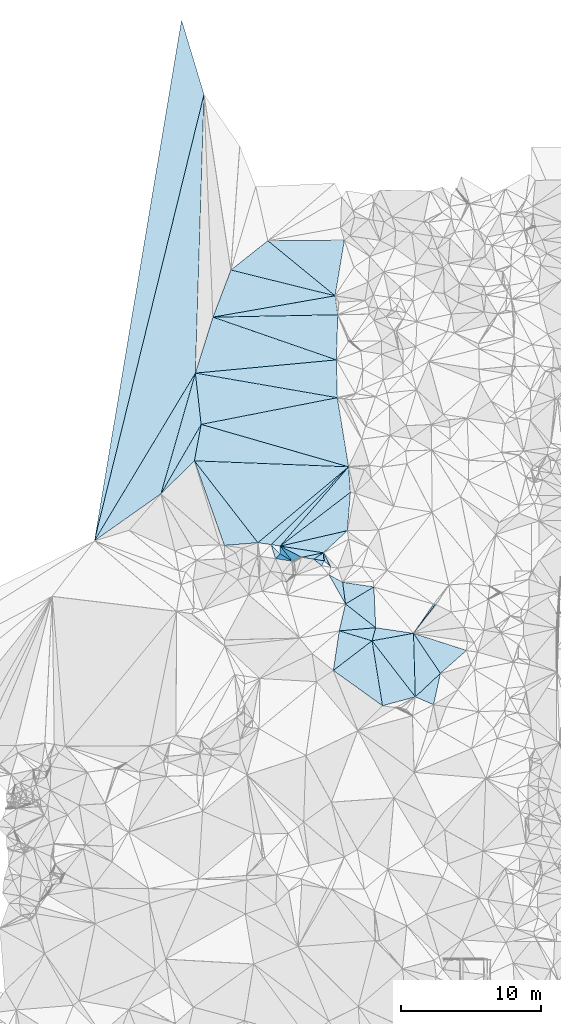
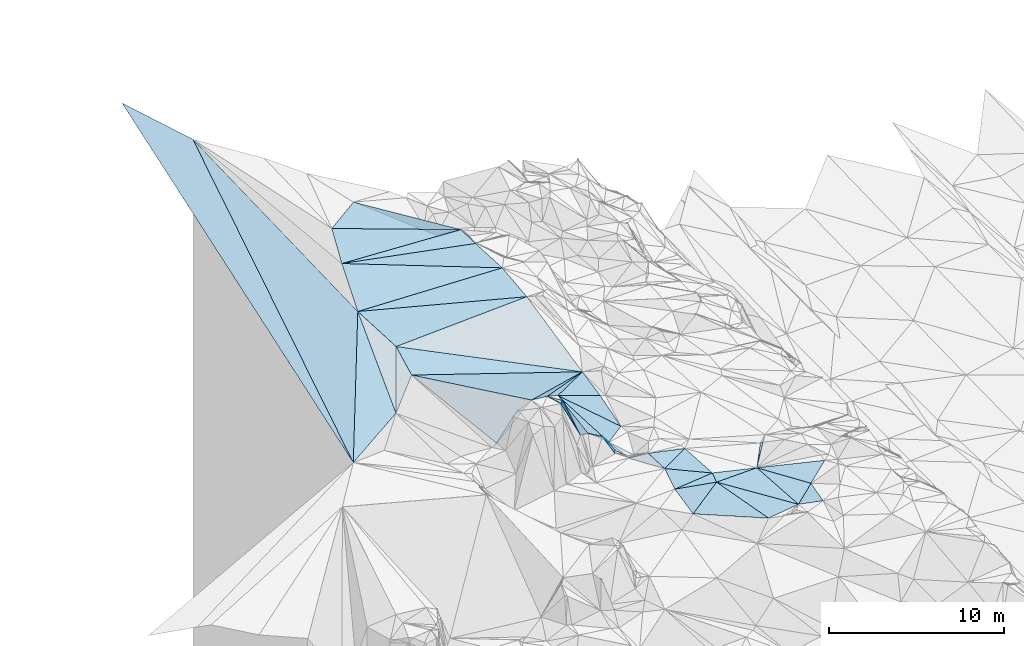
# One storey, part 124 of 275: 45 plates.
"""IFC2X3 building model written with IfcOpenShell, lengths in millimetres."""

import ifcopenshell
import ifcopenshell.guid

model = None  # the IFC model being written
_history = None  # IfcOwnerHistory: only IFC2X3 demands one
_inside = {}  # id of a spatial element -> (the spatial element, [elements in it])
_under = {}  # id of a project, library or spatial element -> (it, [spatial elements below it])
_declared = {}  # id of a project -> (the project, [libraries it declares])
_typed = {}  # id of a type object -> (the type object, [elements of that type])
_made_of = {}  # id of a material, layer set ... -> (it, [elements and type objects made of it])


def new_model(schema):
    """Start an empty IFC model of exactly this schema.

    Asked for "IFC4X3", IfcOpenShell would pick the latest addendum, in which some entities
    have other attributes; the version numbers below select the first issue.
    IFC2X3 requires an IfcOwnerHistory on every rooted entity: one is made here for all.
    """
    global model, _history
    if schema == "IFC4X3":
        model = ifcopenshell.file(schema_version=(4, 3, 0, 0))
    else:
        model = ifcopenshell.file(schema=schema)
    _inside.clear()
    _under.clear()
    _declared.clear()
    _typed.clear()
    _made_of.clear()
    _history = None
    if model.schema == "IFC2X3":
        org = make("IfcOrganization", Name="unknown")
        user = make(
            "IfcPersonAndOrganization",
            ThePerson=make("IfcPerson", FamilyName="unknown"),
            TheOrganization=org,
        )
        app = make(
            "IfcApplication",
            ApplicationDeveloper=org,
            Version="unknown",
            ApplicationFullName="unknown",
            ApplicationIdentifier="unknown",
        )
        _history = make(
            "IfcOwnerHistory",
            OwningUser=user,
            OwningApplication=app,
            ChangeAction="ADDED",
            CreationDate=0,
        )
    return model


def make(cls, **values):
    """One entity of the class cls with the attributes given. An attribute that is None is left unset."""
    return model.create_entity(
        cls, **{name: value for name, value in values.items() if value is not None}
    )


def rooted(cls, **values):
    """An entity with a GlobalId (a new one), such as an element, a storey or a relation."""
    return make(cls, GlobalId=ifcopenshell.guid.new(), OwnerHistory=_history, **values)


def si_unit(unit_type, name, prefix=None):
    """IfcSIUnit, for example si_unit("LENGTHUNIT", "METRE", prefix="MILLI")."""
    return make("IfcSIUnit", UnitType=unit_type, Prefix=prefix, Name=name)


def assignment(units):
    """IfcUnitAssignment: the units of a project."""
    return None if units is None else make("IfcUnitAssignment", Units=units)


def point(xyz):
    """IfcCartesianPoint."""
    return None if xyz is None else make("IfcCartesianPoint", Coordinates=xyz)


def direction(xyz):
    """IfcDirection."""
    return None if xyz is None else make("IfcDirection", DirectionRatios=xyz)


def frame(location, z_axis=None, x_axis=None):
    """IfcAxis2Placement3D, a coordinate frame: its origin and axes. An axis left out is left unset."""
    return make(
        "IfcAxis2Placement3D",
        Location=point(location),
        Axis=direction(z_axis),
        RefDirection=direction(x_axis),
    )


def origin_with_axes():
    """The frame at (0, 0, 0) with the z axis (0, 0, 1) and the x axis (1, 0, 0) written out."""
    return frame((0.0, 0.0, 0.0), z_axis=(0.0, 0.0, 1.0), x_axis=(1.0, 0.0, 0.0))


def place(relative_to, where):
    """IfcLocalPlacement: puts the frame where relative to a parent placement (None: the world)."""
    return make(
        "IfcLocalPlacement", PlacementRelTo=relative_to, RelativePlacement=where
    )


def context(
    kind, dimensions, precision=None, world=None, true_north=None, identifier=None
):
    """IfcGeometricRepresentationContext, for example the 3D "Model" context."""
    return make(
        "IfcGeometricRepresentationContext",
        ContextIdentifier=identifier,
        ContextType=kind,
        CoordinateSpaceDimension=dimensions,
        Precision=precision,
        WorldCoordinateSystem=world,
        TrueNorth=true_north,
    )


def subcontext(parent, identifier, kind, view, scale=None):
    """IfcGeometricRepresentationSubContext, for example "Body" below "Model"."""
    return make(
        "IfcGeometricRepresentationSubContext",
        ContextIdentifier=identifier,
        ContextType=kind,
        ParentContext=parent,
        TargetScale=scale,
        TargetView=view,
    )


def project(units=None, contexts=None):
    """IfcProject with its units and contexts."""
    return rooted(
        "IfcProject",
        Name="project",
        RepresentationContexts=contexts,
        UnitsInContext=assignment(units),
    )


def spatial(cls, under=None, at=None, **own):
    """A site, building, storey or space (cls), placed at a placement, below another one or the project."""
    s = rooted(cls, ObjectPlacement=at, **own)
    if under is not None:
        _under.setdefault(under.id(), (under, []))[1].append(s)
    return s


def polyline(points):
    """IfcPolyline through the points."""
    return make("IfcPolyline", Points=[point(p) for p in points])


def outline(outer, holes=None, kind="AREA"):
    """IfcArbitraryClosedProfileDef: a profile drawn as a closed curve; with holes, ...WithVoids."""
    if holes is None:
        return make("IfcArbitraryClosedProfileDef", ProfileType=kind, OuterCurve=outer)
    return make(
        "IfcArbitraryProfileDefWithVoids",
        ProfileType=kind,
        OuterCurve=outer,
        InnerCurves=holes,
    )


def extrude(swept, where, along, depth):
    """IfcExtrudedAreaSolid: the profile swept, set in the frame where, extruded along a direction by depth."""
    return make(
        "IfcExtrudedAreaSolid",
        SweptArea=swept,
        Position=where,
        ExtrudedDirection=direction(along),
        Depth=depth,
    )


def shape(context_of_items, identifier, shape_type, items):
    """IfcShapeRepresentation: the items that make up one representation, for example the "Body"."""
    return make(
        "IfcShapeRepresentation",
        ContextOfItems=context_of_items,
        RepresentationIdentifier=identifier,
        RepresentationType=shape_type,
        Items=items,
    )


def material(Name=None, Category=None):
    """IfcMaterial."""
    return make("IfcMaterial", Name=Name, Category=Category)


def made_of(thing, what):
    """Note that an element or type object is made of a material, layer set ...; save() writes the relation."""
    if what is not None:
        _made_of.setdefault(what.id(), (what, []))[1].append(thing)
    return thing


def type_object(cls, material=None, **own):
    """A type object (cls), such as IfcWallType, which elements share."""
    return made_of(rooted(cls, **own), material)


def element(
    cls,
    number,
    at=None,
    inside=None,
    cuts=None,
    type_object=None,
    material=None,
    context=None,
    identifier="Body",
    shape_type=None,
    held_by="IfcProductDefinitionShape",
    body=None,
    shapes=None,
    **own,
):
    """One element of the class cls, such as IfcWall. Its Tag is "e" and its number.

    at: its placement. inside: the storey or other place that contains it. cuts: it is an
    opening in that element (IfcRelVoidsElement). A single representation is given by context,
    identifier, shape_type and body (its items); several are given by shapes. held_by: the class
    of the entity that holds the representations. save() writes the other relations.
    """
    e = rooted(cls, Tag="e%d" % number, ObjectPlacement=at, **own)
    if body is not None:
        shapes = [shape(context, identifier, shape_type, body)]
    if shapes is not None:
        e.Representation = make(held_by, Representations=shapes)
    if inside is not None:
        _inside.setdefault(inside.id(), (inside, []))[1].append(e)
    if cuts is not None:
        rooted(
            "IfcRelVoidsElement", RelatingBuildingElement=cuts, RelatedOpeningElement=e
        )
    if type_object is not None:
        _typed.setdefault(type_object.id(), (type_object, []))[1].append(e)
    return made_of(e, material)


def aggregate(whole, parts):
    """IfcRelAggregates: a whole, such as a stair, and the parts it consists of."""
    return rooted("IfcRelAggregates", RelatingObject=whole, RelatedObjects=parts)


def save(model, path):
    """Write the relations noted so far, then the file.

    IfcRelAggregates (storeys below a building ...), IfcRelContainedInSpatialStructure (elements
    in a storey), IfcRelDefinesByType, IfcRelAssociatesMaterial and IfcRelDeclares: one each for
    every whole, place, type object, material and project.
    """
    for whole, parts in _under.values():
        aggregate(whole, parts)
    for where, things in _inside.values():
        rooted(
            "IfcRelContainedInSpatialStructure",
            RelatedElements=things,
            RelatingStructure=where,
        )
    for kind, things in _typed.values():
        rooted("IfcRelDefinesByType", RelatedObjects=things, RelatingType=kind)
    for what, things in _made_of.values():
        rooted("IfcRelAssociatesMaterial", RelatedObjects=things, RelatingMaterial=what)
    for by, libraries in _declared.values():
        rooted("IfcRelDeclares", RelatingContext=by, RelatedDefinitions=libraries)
    model.write(path)


model = new_model("IFC2X3")

# Units and contexts
model_context = context("Model", 3, precision=1e-05, world=origin_with_axes())
body_context = subcontext(model_context, "Body", "Model", "MODEL_VIEW")
ifc_project = project(units=[si_unit("LENGTHUNIT", "METRE", prefix="MILLI"), si_unit("AREAUNIT", "SQUARE_METRE"), si_unit("VOLUMEUNIT", "CUBIC_METRE"), si_unit("MASSUNIT", "GRAM", prefix="KILO"), si_unit("TIMEUNIT", "SECOND"), si_unit("PLANEANGLEUNIT", "RADIAN"), si_unit("SOLIDANGLEUNIT", "STERADIAN"), si_unit("THERMODYNAMICTEMPERATUREUNIT", "DEGREE_CELSIUS"), si_unit("LUMINOUSINTENSITYUNIT", "LUMEN")], contexts=[model_context])

# Site, building, storey
site_placement = place(None, origin_with_axes())
site = spatial("IfcSite", under=ifc_project, at=site_placement, CompositionType="ELEMENT")
building_placement = place(site_placement, origin_with_axes())
building = spatial("IfcBuilding", under=site, at=building_placement, Name="Undefined", CompositionType="ELEMENT")
storey_placement = place(building_placement, origin_with_axes())
storey = spatial("IfcBuildingStorey", under=building, at=storey_placement, Name="Undefined", CompositionType="ELEMENT", Elevation=0.0)

# Plates
ifc_material = material()
plate_type_1 = type_object("IfcPlateType", PredefinedType="NOTDEFINED")
plate_1_placement = place(storey_placement, frame((-114175.597953139, 107744.508860953, 53629.505337816), z_axis=(-0.0888352530172731, 0.115964494229385, -0.989272729786625), x_axis=(0.983479054824188, -0.147062294758909, -0.105553920734222)))
element("IfcPlate", 1, at=plate_1_placement, inside=storey, type_object=plate_type_1, material=ifc_material, Name="00", context=body_context, shape_type="SweptSolid", body=[
    extrude(outline(polyline([(0.0, 0.0), (2273.71948242188, -1.44063960760832e-08), (449.747650146484, 1510.40625), (0.0, 0.0)])), frame((-8.85201319254618e-08, 2.18876761149539e-07, -0.5000001331573), z_axis=(0.0, 0.0, 1.0), x_axis=(1.0, 0.0, 0.0)), (0.0, 0.0, 1.0), 1.0),
])
plate_type_2 = type_object("IfcPlateType", PredefinedType="NOTDEFINED")
plate_2_placement = place(storey_placement, frame((-114717.214245246, 128235.26902347, 57009.5101605572), z_axis=(-0.191774139395289, 0.0595690884011471, -0.979629625504585), x_axis=(-0.969075368389477, -0.169430387431532, 0.179405334913988)))
element("IfcPlate", 2, at=plate_2_placement, inside=storey, type_object=plate_type_2, material=ifc_material, Name="00", context=body_context, shape_type="SweptSolid", body=[
    extrude(outline(polyline([(0.0, 0.0), (9013.1103515625, -1.55414454638958e-08), (7191.712890625, 3112.06518554688), (0.0, 0.0)])), frame((-8.85201319254618e-08, 2.18876761149539e-07, -0.5000001331573), z_axis=(0.0, 0.0, 1.0), x_axis=(1.0, 0.0, 0.0)), (0.0, 0.0, 1.0), 1.0),
])
plate_type_3 = type_object("IfcPlateType", PredefinedType="NOTDEFINED")
plate_3_placement = place(storey_placement, frame((-111809.075701593, 104493.734694822, 53399.5000545148), z_axis=(-0.0171716564030064, -0.00419582616688953, -0.999843752422925), x_axis=(-0.78594217536598, 0.618203853974856, 0.0109037567666122)))
element("IfcPlate", 3, at=plate_3_placement, inside=storey, type_object=plate_type_3, material=ifc_material, Name="00", context=body_context, shape_type="SweptSolid", body=[
    extrude(outline(polyline([(0.0, 0.0), (2751.34521484375, -1.12322595668957e-08), (1905.21350097656, 2211.845703125), (0.0, 0.0)])), frame((-8.85201319254618e-08, 2.18876761149539e-07, -0.5000001331573), z_axis=(0.0, 0.0, 1.0), x_axis=(1.0, 0.0, 0.0)), (0.0, 0.0, 1.0), 1.0),
])
plate_type_4 = type_object("IfcPlateType", PredefinedType="NOTDEFINED")
plate_4_placement = place(storey_placement, frame((-114625.698750157, 123650.722093061, 57089.5115961306), z_axis=(-0.198291460633305, -0.0813843944624339, -0.97675845375297), x_axis=(-0.932372262019334, 0.322983202655929, 0.162369380792902)))
element("IfcPlate", 4, at=plate_4_placement, inside=storey, type_object=plate_type_4, material=ifc_material, Name="00", context=body_context, shape_type="SweptSolid", body=[
    extrude(outline(polyline([(0.0, 0.0), (9466.0703125, -4.52710082754493e-08), (898.579833984375, 3115.24536132813), (0.0, 0.0)])), frame((-8.85201319254618e-08, 2.18876761149539e-07, -0.5000001331573), z_axis=(0.0, 0.0, 1.0), x_axis=(1.0, 0.0, 0.0)), (0.0, 0.0, 1.0), 1.0),
])
plate_type_5 = type_object("IfcPlateType", PredefinedType="NOTDEFINED")
plate_5_placement = place(storey_placement, frame((-118642.360795545, 110329.474902242, 57659.7423815216), z_axis=(-0.577406623138204, 0.633392594716942, -0.515184833350008), x_axis=(0.603967055467656, -0.0932335429188446, -0.791537303217308)))
element("IfcPlate", 5, at=plate_5_placement, inside=storey, type_object=plate_type_5, material=ifc_material, Name="00", context=body_context, shape_type="SweptSolid", body=[
    extrude(outline(polyline([(0.0, 0.0), (5129.25927734375, -1.20780896395445e-09), (3137.82153320313, 658.009094238281), (0.0, 0.0)])), frame((-8.85201319254618e-08, 2.18876761149539e-07, -0.5000001331573), z_axis=(0.0, 0.0, 1.0), x_axis=(1.0, 0.0, 0.0)), (0.0, 0.0, 1.0), 1.0),
])
plate_type_6 = type_object("IfcPlateType", PredefinedType="NOTDEFINED")
plate_6_placement = place(storey_placement, frame((-124296.566456711, 119036.348111439, 57778.5033523463), z_axis=(0.0879728628907912, 0.0756017327784108, -0.993249794057718), x_axis=(-0.180865765413792, -0.979329450672131, -0.0905615920106607)))
element("IfcPlate", 6, at=plate_6_placement, inside=storey, type_object=plate_type_6, material=ifc_material, Name="00", context=body_context, shape_type="SweptSolid", body=[
    extrude(outline(polyline([(0.0, 0.0), (2661.17236328125, 4.48198989033699e-09), (5444.18359375, 1931.08166503906), (0.0, 0.0)])), frame((-8.85201319254618e-08, 2.18876761149539e-07, -0.5000001331573), z_axis=(0.0, 0.0, 1.0), x_axis=(1.0, 0.0, 0.0)), (0.0, 0.0, 1.0), 1.0),
])
plate_type_7 = type_object("IfcPlateType", PredefinedType="NOTDEFINED")
plate_7_placement = place(storey_placement, frame((-115015.230280666, 108827.624189916, 53109.539986265), z_axis=(-0.158818424803335, 0.358352461276172, -0.91997838096354), x_axis=(-0.680164948815086, 0.635705244451135, 0.365040387602104)))
element("IfcPlate", 7, at=plate_7_placement, inside=storey, type_object=plate_type_7, material=ifc_material, Name="00", context=body_context, shape_type="SweptSolid", body=[
    extrude(outline(polyline([(0.0, 0.0), (712.249938964844, 3.48882167600095e-09), (1189.32971191406, 391.145690917969), (0.0, 0.0)])), frame((-8.85201319254618e-08, 2.18876761149539e-07, -0.5000001331573), z_axis=(0.0, 0.0, 1.0), x_axis=(1.0, 0.0, 0.0)), (0.0, 0.0, 1.0), 1.0),
])
plate_type_8 = type_object("IfcPlateType", PredefinedType="NOTDEFINED")
plate_8_placement = place(storey_placement, frame((-114521.890052395, 126878.41139543, 56799.5139793954), z_axis=(-0.201182998876511, 0.121470308220114, -0.971992986180438), x_axis=(-0.979534076495408, -0.0186705573349574, 0.200410586729069)))
element("IfcPlate", 8, at=plate_8_placement, inside=storey, type_object=plate_type_8, material=ifc_material, Name="00", context=body_context, shape_type="SweptSolid", body=[
    extrude(outline(polyline([(0.0, 0.0), (9116.28515625, -3.88536136597395e-08), (208.08366394043, 1371.16784667969), (0.0, 0.0)])), frame((-8.85201319254618e-08, 2.18876761149539e-07, -0.5000001331573), z_axis=(0.0, 0.0, 1.0), x_axis=(1.0, 0.0, 0.0)), (0.0, 0.0, 1.0), 1.0),
])
plate_type_9 = type_object("IfcPlateType", PredefinedType="NOTDEFINED")
plate_9_placement = place(storey_placement, frame((-109105.956896009, 104092.416596915, 53059.5014098893), z_axis=(0.0520569790283698, -0.0549004783838921, -0.997133896930427), x_axis=(0.566734145687785, 0.823749846956517, -0.0157669829280085)))
element("IfcPlate", 9, at=plate_9_placement, inside=storey, type_object=plate_type_9, material=ifc_material, Name="00", context=body_context, shape_type="SweptSolid", body=[
    extrude(outline(polyline([(0.0, 0.0), (2536.94702148438, 2.07801349461079e-08), (2608.80493164063, 150.454055786133), (0.0, 0.0)])), frame((-8.85201319254618e-08, 2.18876761149539e-07, -0.5000001331573), z_axis=(0.0, 0.0, 1.0), x_axis=(1.0, 0.0, 0.0)), (0.0, 0.0, 1.0), 1.0),
])
plate_type_10 = type_object("IfcPlateType", PredefinedType="NOTDEFINED")
plate_10_placement = place(storey_placement, frame((-111321.488505796, 98914.452061827, 53459.5000135657), z_axis=(-0.00698124411273086, -0.0097450552064453, -0.999928145483295), x_axis=(-0.812924225999217, 0.582369472743528, -1.95594853231937e-10)))
element("IfcPlate", 10, at=plate_10_placement, inside=storey, type_object=plate_type_10, material=ifc_material, Name="00", context=body_context, shape_type="SweptSolid", body=[
    extrude(outline(polyline([(0.0, 0.0), (4330.4619140625, 1.2536474969238e-08), (3314.54248046875, 3336.76611328125), (0.0, 0.0)])), frame((-8.85201319254618e-08, 2.18876761149539e-07, -0.5000001331573), z_axis=(0.0, 0.0, 1.0), x_axis=(1.0, 0.0, 0.0)), (0.0, 0.0, 1.0), 1.0),
])
plate_type_11 = type_object("IfcPlateType", PredefinedType="NOTDEFINED")
plate_11_placement = place(storey_placement, frame((-115500.006719541, 109280.305874613, 53369.7227580388), z_axis=(-0.816770956718138, 0.159652889196233, -0.554433187348154), x_axis=(-0.548211263211113, 0.0848150749108207, 0.832028132911591)))
element("IfcPlate", 11, at=plate_11_placement, inside=storey, type_object=plate_type_11, material=ifc_material, Name="00", context=body_context, shape_type="SweptSolid", body=[
    extrude(outline(polyline([(0.0, 0.0), (1370.14599609375, 1.42608769237995e-09), (264.205413818359, 557.490356445313), (0.0, 0.0)])), frame((-8.85201319254618e-08, 2.18876761149539e-07, -0.5000001331573), z_axis=(0.0, 0.0, 1.0), x_axis=(1.0, 0.0, 0.0)), (0.0, 0.0, 1.0), 1.0),
])
plate_type_12 = type_object("IfcPlateType", PredefinedType="NOTDEFINED")
plate_12_placement = place(storey_placement, frame((-112072.91354946, 103557.076384194, 53419.5024018063), z_axis=(-0.0953909299829093, -0.0240124442606534, -0.995150226346568), x_axis=(0.610593286063744, -0.79096147470314, -0.0394434348062319)))
element("IfcPlate", 12, at=plate_12_placement, inside=storey, type_object=plate_type_12, material=ifc_material, Name="00", context=body_context, shape_type="SweptSolid", body=[
    extrude(outline(polyline([(0.0, 0.0), (5070.55224609375, 7.57427187636495e-09), (4129.35302734375, 2251.36499023438), (0.0, 0.0)])), frame((-8.85201319254618e-08, 2.18876761149539e-07, -0.5000001331573), z_axis=(0.0, 0.0, 1.0), x_axis=(1.0, 0.0, 0.0)), (0.0, 0.0, 1.0), 1.0),
])
plate_type_13 = type_object("IfcPlateType", PredefinedType="NOTDEFINED")
plate_13_placement = place(storey_placement, frame((-119290.788694891, 110435.990824365, 57759.5157436405), z_axis=(-0.237935793014522, -0.0739632443810341, -0.968460632593386), x_axis=(0.697572012528893, -0.706831236116761, -0.117400557860861)))
element("IfcPlate", 13, at=plate_13_placement, inside=storey, type_object=plate_type_13, material=ifc_material, Name="00", context=body_context, shape_type="SweptSolid", body=[
    extrude(outline(polyline([(0.0, 0.0), (936.963195800781, -3.71255737263709e-09), (923.408752441406, 493.27099609375), (0.0, 0.0)])), frame((-8.85201319254618e-08, 2.18876761149539e-07, -0.5000001331573), z_axis=(0.0, 0.0, 1.0), x_axis=(1.0, 0.0, 0.0)), (0.0, 0.0, 1.0), 1.0),
])
plate_type_14 = type_object("IfcPlateType", PredefinedType="NOTDEFINED")
plate_14_placement = place(storey_placement, frame((-113748.474838146, 116002.542333792, 54159.6544594672), z_axis=(-0.700561983704708, 0.178009584636807, -0.691032195172668), x_axis=(0.0667342972903897, -0.947798929716495, -0.311807187847593)))
element("IfcPlate", 14, at=plate_14_placement, inside=storey, type_object=plate_type_14, material=ifc_material, Name="00", context=body_context, shape_type="SweptSolid", body=[
    extrude(outline(polyline([(0.0, 0.0), (1924.26611328125, -3.02679836750031e-09), (3959.2236328125, 7260.27197265625), (0.0, 0.0)])), frame((-8.85201319254618e-08, 2.18876761149539e-07, -0.5000001331573), z_axis=(0.0, 0.0, 1.0), x_axis=(1.0, 0.0, 0.0)), (0.0, 0.0, 1.0), 1.0),
])
plate_type_15 = type_object("IfcPlateType", PredefinedType="NOTDEFINED")
plate_15_placement = place(storey_placement, frame((-114420.968302615, 104268.365415696, 53319.5004877625), z_axis=(0.033245760197973, -0.0306942337305773, -0.998975767195857), x_axis=(0.995834992084474, 0.0859205522479929, 0.0305012662280693)))
element("IfcPlate", 15, at=plate_15_placement, inside=storey, type_object=plate_type_15, material=ifc_material, Name="00", context=body_context, shape_type="SweptSolid", body=[
    extrude(outline(polyline([(0.0, 0.0), (2622.84204101563, -2.0270817913115e-08), (2280.27465820313, 911.014587402344), (0.0, 0.0)])), frame((-8.85201319254618e-08, 2.18876761149539e-07, -0.5000001331573), z_axis=(0.0, 0.0, 1.0), x_axis=(1.0, 0.0, 0.0)), (0.0, 0.0, 1.0), 1.0),
])
plate_type_16 = type_object("IfcPlateType", PredefinedType="NOTDEFINED")
plate_16_placement = place(storey_placement, frame((-117784.431067585, 109254.607917991, 55239.7533326028), z_axis=(-0.496927527723947, 0.713956818076802, -0.493283583866132), x_axis=(-0.308206750301059, 0.386172903025349, 0.869413071007007)))
element("IfcPlate", 16, at=plate_16_placement, inside=storey, type_object=plate_type_16, material=ifc_material, Name="00", context=body_context, shape_type="SweptSolid", body=[
    extrude(outline(polyline([(0.0, 0.0), (2783.48706054688, -5.05679054185748e-09), (-344.783355712891, 702.014526367188), (0.0, 0.0)])), frame((-8.85201319254618e-08, 2.18876761149539e-07, -0.5000001331573), z_axis=(0.0, 0.0, 1.0), x_axis=(1.0, 0.0, 0.0)), (0.0, 0.0, 1.0), 1.0),
])
plate_type_17 = type_object("IfcPlateType", PredefinedType="NOTDEFINED")
plate_17_placement = place(storey_placement, frame((-113748.225602674, 116002.262273868, 54159.5490826405), z_axis=(-0.201992086437844, -0.382087283046879, -0.901780741172898), x_axis=(-0.591796690475392, -0.686038676201034, 0.423234700726093)))
element("IfcPlate", 17, at=plate_17_placement, inside=storey, type_object=plate_type_17, material=ifc_material, Name="00", context=body_context, shape_type="SweptSolid", body=[
    extrude(outline(polyline([(0.0, 0.0), (8269.6435546875, 7.33416527509689e-08), (8622.48828125, 563.560668945313), (0.0, 0.0)])), frame((-8.85201319254618e-08, 2.18876761149539e-07, -0.5000001331573), z_axis=(0.0, 0.0, 1.0), x_axis=(1.0, 0.0, 0.0)), (0.0, 0.0, 1.0), 1.0),
])
plate_type_18 = type_object("IfcPlateType", PredefinedType="NOTDEFINED")
plate_18_placement = place(storey_placement, frame((-114420.971739456, 104268.354127584, 53319.5008599796), z_axis=(0.0263762612855262, -0.0532672483761291, -0.99823188342741), x_axis=(0.956259724316715, -0.28967025185498, 0.0407244992601904)))
element("IfcPlate", 18, at=plate_18_placement, inside=storey, type_object=plate_type_18, material=ifc_material, Name="00", context=body_context, shape_type="SweptSolid", body=[
    extrude(outline(polyline([(0.0, 0.0), (2455.5244140625, 1.11976987682283e-08), (423.616241455078, 2835.03955078125), (0.0, 0.0)])), frame((-8.85201319254618e-08, 2.18876761149539e-07, -0.5000001331573), z_axis=(0.0, 0.0, 1.0), x_axis=(1.0, 0.0, 0.0)), (0.0, 0.0, 1.0), 1.0),
])
plate_type_19 = type_object("IfcPlateType", PredefinedType="NOTDEFINED")
plate_19_placement = place(storey_placement, frame((-111809.128529451, 104493.743494723, 53399.5038083197), z_axis=(-0.122828438722152, 0.01340443171131, -0.992337390130784), x_axis=(0.981590741857416, -0.145724371740912, -0.123466687736106)))
element("IfcPlate", 19, at=plate_19_placement, inside=storey, type_object=plate_type_19, material=ifc_material, Name="00", context=body_context, shape_type="SweptSolid", body=[
    extrude(outline(polyline([(0.0, 0.0), (2753.779296875, -2.02271621674299e-08), (-124.919235229492, 965.243591308594), (0.0, 0.0)])), frame((-8.85201319254618e-08, 2.18876761149539e-07, -0.5000001331573), z_axis=(0.0, 0.0, 1.0), x_axis=(1.0, 0.0, 0.0)), (0.0, 0.0, 1.0), 1.0),
])
plate_type_20 = type_object("IfcPlateType", PredefinedType="NOTDEFINED")
plate_20_placement = place(storey_placement, frame((-107669.116230378, 98987.4263167303, 53349.5055881655), z_axis=(0.0363677510539843, -0.144878476450024, -0.98878087246103), x_axis=(-0.915698201667028, 0.391420557065779, -0.0910315932524925)))
element("IfcPlate", 20, at=plate_20_placement, inside=storey, type_object=plate_type_20, material=ifc_material, Name="00", context=body_context, shape_type="SweptSolid", body=[
    extrude(outline(polyline([(0.0, 0.0), (1428.07568359375, 3.49973561242223e-09), (458.519134521484, 2265.14013671875), (0.0, 0.0)])), frame((-8.85201319254618e-08, 2.18876761149539e-07, -0.5000001331573), z_axis=(0.0, 0.0, 1.0), x_axis=(1.0, 0.0, 0.0)), (0.0, 0.0, 1.0), 1.0),
])
plate_type_21 = type_object("IfcPlateType", PredefinedType="NOTDEFINED")
plate_21_placement = place(storey_placement, frame((-109106.015648827, 104092.425564487, 53059.5013921766), z_axis=(-0.0654518483558602, -0.0369561169105363, -0.997171149286669), x_axis=(0.557126888216423, -0.830407173927717, -0.0057927468154539)))
element("IfcPlate", 21, at=plate_21_placement, inside=storey, type_object=plate_type_21, material=ifc_material, Name="00", context=body_context, shape_type="SweptSolid", body=[
    extrude(outline(polyline([(0.0, 0.0), (3452.59326171875, 1.2099917512387e-08), (3846.03662109375, 2432.30395507813), (0.0, 0.0)])), frame((-8.85201319254618e-08, 2.18876761149539e-07, -0.5000001331573), z_axis=(0.0, 0.0, 1.0), x_axis=(1.0, 0.0, 0.0)), (0.0, 0.0, 1.0), 1.0),
])
plate_type_22 = type_object("IfcPlateType", PredefinedType="NOTDEFINED")
plate_22_placement = place(storey_placement, frame((-108976.877491179, 99546.4578334802, 53219.5035803239), z_axis=(-0.113577845699346, -0.0381694953599851, -0.992795629820287), x_axis=(-0.610593286071158, 0.790961474697853, 0.0394434347974803)))
element("IfcPlate", 22, at=plate_22_placement, inside=storey, type_object=plate_type_22, material=ifc_material, Name="00", context=body_context, shape_type="SweptSolid", body=[
    extrude(outline(polyline([(0.0, 0.0), (5070.55224609375, 7.57427187636495e-09), (3668.23950195313, 2692.97583007813), (0.0, 0.0)])), frame((-8.85201319254618e-08, 2.18876761149539e-07, -0.5000001331573), z_axis=(0.0, 0.0, 1.0), x_axis=(1.0, 0.0, 0.0)), (0.0, 0.0, 1.0), 1.0),
])
plate_type_23 = type_object("IfcPlateType", PredefinedType="NOTDEFINED")
plate_23_placement = place(storey_placement, frame((-107182.459071164, 101225.383532245, 53039.5000585789), z_axis=(-0.017341739821805, -0.00466004736958707, -0.999838761010227), x_axis=(-0.557126888223752, 0.830407173922953, 0.00579274679342325)))
element("IfcPlate", 23, at=plate_23_placement, inside=storey, type_object=plate_type_23, material=ifc_material, Name="00", context=body_context, shape_type="SweptSolid", body=[
    extrude(outline(polyline([(0.0, 0.0), (3452.59326171875, 1.2099917512387e-08), (326.479248046875, 2464.63208007813), (0.0, 0.0)])), frame((-8.85201319254618e-08, 2.18876761149539e-07, -0.5000001331573), z_axis=(0.0, 0.0, 1.0), x_axis=(1.0, 0.0, 0.0)), (0.0, 0.0, 1.0), 1.0),
])
plate_type_24 = type_object("IfcPlateType", PredefinedType="NOTDEFINED")
plate_24_placement = place(storey_placement, frame((-113971.452191215, 106194.654404989, 53429.5007954983), z_axis=(0.026186873571278, 0.0509010842620849, -0.998360319360453), x_axis=(0.785942175355675, -0.618203853988048, -0.0109037567614771)))
element("IfcPlate", 24, at=plate_24_placement, inside=storey, type_object=plate_type_24, material=ifc_material, Name="00", context=body_context, shape_type="SweptSolid", body=[
    extrude(outline(polyline([(0.0, 0.0), (2751.34521484375, -1.12322595668957e-08), (838.717041015625, 1794.75732421875), (0.0, 0.0)])), frame((-8.85201319254618e-08, 2.18876761149539e-07, -0.5000001331573), z_axis=(0.0, 0.0, 1.0), x_axis=(1.0, 0.0, 0.0)), (0.0, 0.0, 1.0), 1.0),
])
plate_type_25 = type_object("IfcPlateType", PredefinedType="NOTDEFINED")
plate_25_placement = place(storey_placement, frame((-113748.267038224, 116002.5234804, 54159.5258687341), z_axis=(-0.284960475190707, 0.14031170090747, -0.94821419213569), x_axis=(-0.955506297924097, 0.0370508007382355, 0.292634503762017)))
element("IfcPlate", 25, at=plate_25_placement, inside=storey, type_object=plate_type_25, material=ifc_material, Name="00", context=body_context, shape_type="SweptSolid", body=[
    extrude(outline(polyline([(0.0, 0.0), (11543.41015625, -8.52014636620879e-08), (11250.595703125, 2645.013671875), (0.0, 0.0)])), frame((-8.85201319254618e-08, 2.18876761149539e-07, -0.5000001331573), z_axis=(0.0, 0.0, 1.0), x_axis=(1.0, 0.0, 0.0)), (0.0, 0.0, 1.0), 1.0),
])
plate_type_26 = type_object("IfcPlateType", PredefinedType="NOTDEFINED")
plate_26_placement = place(storey_placement, frame((-115157.158370398, 108283.581610977, 53309.5467927043), z_axis=(0.387658318010558, 0.168012205508297, -0.906362470139548), x_axis=(0.842846558149478, -0.462756461873198, 0.274711005258577)))
element("IfcPlate", 26, at=plate_26_placement, inside=storey, type_object=plate_type_26, material=ifc_material, Name="00", context=body_context, shape_type="SweptSolid", body=[
    extrude(outline(polyline([(0.0, 0.0), (1164.86047363281, -3.63797880709171e-11), (1999.12353515625, 1337.01354980469), (0.0, 0.0)])), frame((-8.85201319254618e-08, 2.18876761149539e-07, -0.5000001331573), z_axis=(0.0, 0.0, 1.0), x_axis=(1.0, 0.0, 0.0)), (0.0, 0.0, 1.0), 1.0),
])
plate_type_27 = type_object("IfcPlateType", PredefinedType="NOTDEFINED")
plate_27_placement = place(storey_placement, frame((-118637.424458574, 109774.050873788, 57649.8104670121), z_axis=(-0.708054053871445, 0.595825482304486, -0.379013787919172), x_axis=(0.32693776520918, -0.199140875974704, -0.923826070857526)))
element("IfcPlate", 27, at=plate_27_placement, inside=storey, type_object=plate_type_27, material=ifc_material, Name="00", context=body_context, shape_type="SweptSolid", body=[
    extrude(outline(polyline([(0.0, 0.0), (2608.71606445313, -3.68527253158391e-09), (-146.508850097656, 471.2060546875), (0.0, 0.0)])), frame((-8.85201319254618e-08, 2.18876761149539e-07, -0.5000001331573), z_axis=(0.0, 0.0, 1.0), x_axis=(1.0, 0.0, 0.0)), (0.0, 0.0, 1.0), 1.0),
])
plate_type_28 = type_object("IfcPlateType", PredefinedType="NOTDEFINED")
plate_28_placement = place(storey_placement, frame((-115682.42812715, 108926.389055409, 53419.7282313698), z_axis=(-0.774943131228018, 0.322623322517366, -0.543486278695581), x_axis=(-0.4320402902343, 0.357223686924225, 0.828089623841843)))
element("IfcPlate", 28, at=plate_28_placement, inside=storey, type_object=plate_type_28, material=ifc_material, Name="00", context=body_context, shape_type="SweptSolid", body=[
    extrude(outline(polyline([(0.0, 0.0), (1316.28259277344, -4.93309926241636e-09), (6.22966527938843, 401.324310302734), (0.0, 0.0)])), frame((-8.85201319254618e-08, 2.18876761149539e-07, -0.5000001331573), z_axis=(0.0, 0.0, 1.0), x_axis=(1.0, 0.0, 0.0)), (0.0, 0.0, 1.0), 1.0),
])
plate_type_29 = type_object("IfcPlateType", PredefinedType="NOTDEFINED")
plate_29_placement = place(storey_placement, frame((-117108.651808509, 109530.819502839, 54959.6748090165), z_axis=(-0.438602746325198, -0.620240328021705, -0.650330351753262), x_axis=(0.745835309830281, 0.152484027100222, -0.648442990624208)))
element("IfcPlate", 29, at=plate_29_placement, inside=storey, type_object=plate_type_29, material=ifc_material, Name="00", context=body_context, shape_type="SweptSolid", body=[
    extrude(outline(polyline([(0.0, 0.0), (2097.33154296875, 9.41508915275335e-09), (910.967041015625, 355.582672119141), (0.0, 0.0)])), frame((-8.85201319254618e-08, 2.18876761149539e-07, -0.5000001331573), z_axis=(0.0, 0.0, 1.0), x_axis=(1.0, 0.0, 0.0)), (0.0, 0.0, 1.0), 1.0),
])
plate_type_30 = type_object("IfcPlateType", PredefinedType="NOTDEFINED")
plate_30_placement = place(storey_placement, frame((-117784.654040167, 109254.249696342, 55239.8334033696), z_axis=(-0.942873633598072, -0.00249281004465667, -0.333141256772033), x_axis=(-0.32693776522658, 0.199140875953153, 0.923826070856014)))
element("IfcPlate", 30, at=plate_30_placement, inside=storey, type_object=plate_type_30, material=ifc_material, Name="00", context=body_context, shape_type="SweptSolid", body=[
    extrude(outline(polyline([(0.0, 0.0), (2608.71606445313, -3.68527253158391e-09), (2730.19360351563, 542.073120117188), (0.0, 0.0)])), frame((-8.85201319254618e-08, 2.18876761149539e-07, -0.5000001331573), z_axis=(0.0, 0.0, 1.0), x_axis=(1.0, 0.0, 0.0)), (0.0, 0.0, 1.0), 1.0),
])
plate_type_31 = type_object("IfcPlateType", PredefinedType="NOTDEFINED")
plate_31_placement = place(storey_placement, frame((-124777.639149053, 116430.35505834, 57537.6473327106), z_axis=(0.572374471386604, 0.418292424328372, -0.705279315062054), x_axis=(0.612526603366505, -0.789932357012951, 0.0286012501869388)))
element("IfcPlate", 31, at=plate_31_placement, inside=storey, type_object=plate_type_31, material=ifc_material, Name="00", context=body_context, shape_type="SweptSolid", body=[
    extrude(outline(polyline([(0.0, 0.0), (7412.263671875, -1.48429535329342e-08), (6040.2724609375, 2852.76000976563), (0.0, 0.0)])), frame((-8.85201319254618e-08, 2.18876761149539e-07, -0.5000001331573), z_axis=(0.0, 0.0, 1.0), x_axis=(1.0, 0.0, 0.0)), (0.0, 0.0, 1.0), 1.0),
])
plate_type_32 = type_object("IfcPlateType", PredefinedType="NOTDEFINED")
plate_32_placement = place(storey_placement, frame((-120237.862748497, 110574.829277821, 57749.5397327971), z_axis=(-0.291979280019336, -0.259733636525134, -0.920481688083375), x_axis=(-0.612526603366657, 0.789932357012882, -0.0286012501856049)))
element("IfcPlate", 32, at=plate_32_placement, inside=storey, type_object=plate_type_32, material=ifc_material, Name="00", context=body_context, shape_type="SweptSolid", body=[
    extrude(outline(polyline([(0.0, 0.0), (7412.263671875, -1.48429535329342e-08), (414.98388671875, 9180.87109375), (0.0, 0.0)])), frame((-8.85201319254618e-08, 2.18876761149539e-07, -0.5000001331573), z_axis=(0.0, 0.0, 1.0), x_axis=(1.0, 0.0, 0.0)), (0.0, 0.0, 1.0), 1.0),
])
plate_type_33 = type_object("IfcPlateType", PredefinedType="NOTDEFINED")
plate_33_placement = place(storey_placement, frame((-113748.156409522, 116002.205096775, 54159.5671176155), z_axis=(-0.0636906963705584, -0.496469894409202, -0.865714236420511), x_axis=(-0.641432552950062, -0.644196200206586, 0.416623973932563)))
element("IfcPlate", 33, at=plate_33_placement, inside=storey, type_object=plate_type_33, material=ifc_material, Name="00", context=body_context, shape_type="SweptSolid", body=[
    extrude(outline(polyline([(0.0, 0.0), (8640.8857421875, -4.23751771450043e-08), (9154.6865234375, 807.655883789063), (0.0, 0.0)])), frame((-8.85201319254618e-08, 2.18876761149539e-07, -0.5000001331573), z_axis=(0.0, 0.0, 1.0), x_axis=(1.0, 0.0, 0.0)), (0.0, 0.0, 1.0), 1.0),
])
plate_type_34 = type_object("IfcPlateType", PredefinedType="NOTDEFINED")
plate_34_placement = place(storey_placement, frame((-113839.653836115, 111435.86421823, 53159.7243188242), z_axis=(-0.639892452448946, 0.535341328427964, -0.551314167581295), x_axis=(-0.719704770773683, -0.668971314096347, 0.18574828085828)))
element("IfcPlate", 34, at=plate_34_placement, inside=storey, type_object=plate_type_34, material=ifc_material, Name="00", context=body_context, shape_type="SweptSolid", body=[
    extrude(outline(polyline([(0.0, 0.0), (2368.79711914063, 6.14090822637081e-09), (5032.59619140625, 4383.31787109375), (0.0, 0.0)])), frame((-8.85201319254618e-08, 2.18876761149539e-07, -0.5000001331573), z_axis=(0.0, 0.0, 1.0), x_axis=(1.0, 0.0, 0.0)), (0.0, 0.0, 1.0), 1.0),
])
plate_type_35 = type_object("IfcPlateType", PredefinedType="NOTDEFINED")
plate_35_placement = place(storey_placement, frame((-118642.41922922, 110329.237190779, 57659.6489003753), z_axis=(-0.69428372257638, 0.157978337402935, -0.702148814338449), x_axis=(0.666089907787776, 0.510536330001484, -0.543761795726666)))
element("IfcPlate", 35, at=plate_35_placement, inside=storey, type_object=plate_type_35, material=ifc_material, Name="00", context=body_context, shape_type="SweptSolid", body=[
    extrude(outline(polyline([(0.0, 0.0), (7540.06640625, 2.10129655897617e-08), (6210.8603515625, 2442.48071289063), (0.0, 0.0)])), frame((-8.85201319254618e-08, 2.18876761149539e-07, -0.5000001331573), z_axis=(0.0, 0.0, 1.0), x_axis=(1.0, 0.0, 0.0)), (0.0, 0.0, 1.0), 1.0),
])
plate_type_36 = type_object("IfcPlateType", PredefinedType="NOTDEFINED")
plate_36_placement = place(storey_placement, frame((-114556.849543487, 120947.813267611, 56689.5058364136), z_axis=(-0.127096701003743, 0.0845766330778942, -0.988277907135019), x_axis=(-0.975428207156288, -0.191429802329714, 0.109061649831073)))
element("IfcPlate", 36, at=plate_36_placement, inside=storey, type_object=plate_type_36, material=ifc_material, Name="00", context=body_context, shape_type="SweptSolid", body=[
    extrude(outline(polyline([(0.0, 0.0), (9985.177734375, 4.27826307713985e-09), (9725.3583984375, 3700.66259765625), (0.0, 0.0)])), frame((-8.85201319254618e-08, 2.18876761149539e-07, -0.5000001331573), z_axis=(0.0, 0.0, 1.0), x_axis=(1.0, 0.0, 0.0)), (0.0, 0.0, 1.0), 1.0),
])
plate_type_37 = type_object("IfcPlateType", PredefinedType="NOTDEFINED")
plate_37_placement = place(storey_placement, frame((-124296.701581025, 119036.522312315, 57778.5564234658), z_axis=(-0.182398591265921, 0.424009994187889, -0.887099926013408), x_axis=(0.975428207157282, 0.191429802325159, -0.109061649830179)))
element("IfcPlate", 37, at=plate_37_placement, inside=storey, type_object=plate_type_37, material=ifc_material, Name="00", context=body_context, shape_type="SweptSolid", body=[
    extrude(outline(polyline([(0.0, 0.0), (9985.177734375, 4.27826307713985e-09), (10103.2138671875, 5612.224609375), (0.0, 0.0)])), frame((-8.85201319254618e-08, 2.18876761149539e-07, -0.5000001331573), z_axis=(0.0, 0.0, 1.0), x_axis=(1.0, 0.0, 0.0)), (0.0, 0.0, 1.0), 1.0),
])
plate_type_38 = type_object("IfcPlateType", PredefinedType="NOTDEFINED")
plate_38_placement = place(storey_placement, frame((-114625.658229142, 123650.840133666, 57089.5094850068), z_axis=(-0.117246148250419, 0.154695739401072, -0.98098041210393), x_axis=(-0.990259765255077, -0.0929025433520188, 0.103704940845101)))
element("IfcPlate", 38, at=plate_38_placement, inside=storey, type_object=plate_type_38, material=ifc_material, Name="00", context=body_context, shape_type="SweptSolid", body=[
    extrude(outline(polyline([(0.0, 0.0), (10182.7353515625, 2.15368345379829e-09), (8615.291015625, 3922.1484375), (0.0, 0.0)])), frame((-8.85201319254618e-08, 2.18876761149539e-07, -0.5000001331573), z_axis=(0.0, 0.0, 1.0), x_axis=(1.0, 0.0, 0.0)), (0.0, 0.0, 1.0), 1.0),
])
plate_type_39 = type_object("IfcPlateType", PredefinedType="NOTDEFINED")
plate_39_placement = place(storey_placement, frame((-124709.211152206, 122704.831999953, 58145.5085041453), z_axis=(-0.116306827492265, 0.142498277439902, -0.982937924187151), x_axis=(0.990259765254565, 0.0929025433445631, -0.103704940856672)))
element("IfcPlate", 39, at=plate_39_placement, inside=storey, type_object=plate_type_39, material=ifc_material, Name="00", context=body_context, shape_type="SweptSolid", body=[
    extrude(outline(polyline([(0.0, 0.0), (10182.7353515625, 2.15368345379829e-09), (10041.24609375, 2729.63012695313), (0.0, 0.0)])), frame((-8.85201319254618e-08, 2.18876761149539e-07, -0.5000001331573), z_axis=(0.0, 0.0, 1.0), x_axis=(1.0, 0.0, 0.0)), (0.0, 0.0, 1.0), 1.0),
])
plate_type_40 = type_object("IfcPlateType", PredefinedType="NOTDEFINED")
plate_40_placement = place(storey_placement, frame((-114717.212727845, 128235.275075389, 57009.5102717607), z_axis=(-0.188734271982577, 0.0716737385935397, -0.97940913298541), x_axis=(-0.951049195651246, 0.23518724451577, 0.200480391729956)))
element("IfcPlate", 40, at=plate_40_placement, inside=storey, type_object=plate_type_40, material=ifc_material, Name="00", context=body_context, shape_type="SweptSolid", body=[
    extrude(outline(polyline([(0.0, 0.0), (7836.177734375, -5.25033101439476e-08), (5743.962890625, 2668.42236328125), (0.0, 0.0)])), frame((-8.85201319254618e-08, 2.18876761149539e-07, -0.5000001331573), z_axis=(0.0, 0.0, 1.0), x_axis=(1.0, 0.0, 0.0)), (0.0, 0.0, 1.0), 1.0),
])
plate_type_41 = type_object("IfcPlateType", PredefinedType="NOTDEFINED")
plate_41_placement = place(storey_placement, frame((-125698.028713131, 147961.657704097, 57730.5012358328), z_axis=(0.0708421385117003, -0.0029625750514021, -0.997483139987917), x_axis=(0.289173206516656, -0.956991247920447, 0.0233796500517364)))
element("IfcPlate", 41, at=plate_41_placement, inside=storey, type_object=plate_type_41, material=ifc_material, Name="00", context=body_context, shape_type="SweptSolid", body=[
    extrude(outline(polyline([(0.0, 0.0), (5560.39111328125, 1.4042598195374e-08), (33839.94140625, 16779.044921875), (0.0, 0.0)])), frame((-8.85201319254618e-08, 2.18876761149539e-07, -0.5000001331573), z_axis=(0.0, 0.0, 1.0), x_axis=(1.0, 0.0, 0.0)), (0.0, 0.0, 1.0), 1.0),
])
plate_type_42 = type_object("IfcPlateType", PredefinedType="NOTDEFINED")
plate_42_placement = place(storey_placement, frame((-124709.13341632, 122704.812666684, 58145.5030689265), z_axis=(0.0393040937744987, 0.103843668804706, -0.993816723879078), x_axis=(0.111204304573734, -0.988861401441389, -0.098927910033747)))
element("IfcPlate", 42, at=plate_42_placement, inside=storey, type_object=plate_type_42, material=ifc_material, Name="00", context=body_context, shape_type="SweptSolid", body=[
    extrude(outline(polyline([(0.0, 0.0), (3709.77221679688, 3.69618646800518e-09), (8366.5419921875, 3417.99755859375), (0.0, 0.0)])), frame((-8.85201319254618e-08, 2.18876761149539e-07, -0.5000001331573), z_axis=(0.0, 0.0, 1.0), x_axis=(1.0, 0.0, 0.0)), (0.0, 0.0, 1.0), 1.0),
])
plate_type_43 = type_object("IfcPlateType", PredefinedType="NOTDEFINED")
plate_43_placement = place(storey_placement, frame((-127172.979806678, 114067.034397432, 57145.5132737446), z_axis=(-0.164372454225152, 0.159574879923362, -0.973405133533538), x_axis=(-0.816273153459731, -0.576032973223403, 0.043406827807532)))
element("IfcPlate", 43, at=plate_43_placement, inside=storey, type_object=plate_type_43, material=ifc_material, Name="00", context=body_context, shape_type="SweptSolid", body=[
    extrude(outline(polyline([(0.0, 0.0), (5828.576171875, -2.29338183999062e-08), (-6943.3427734375, 5785.47509765625), (0.0, 0.0)])), frame((-8.85201319254618e-08, 2.18876761149539e-07, -0.5000001331573), z_axis=(0.0, 0.0, 1.0), x_axis=(1.0, 0.0, 0.0)), (0.0, 0.0, 1.0), 1.0),
])
plate_type_44 = type_object("IfcPlateType", PredefinedType="NOTDEFINED")
plate_44_placement = place(storey_placement, frame((-124709.086623074, 122704.751597316, 58145.5044967073), z_axis=(0.132892758509438, -0.018293122925106, -0.990961591783152), x_axis=(-0.515038822620462, -0.855509569366322, -0.0532765231258492)))
element("IfcPlate", 44, at=plate_44_placement, inside=storey, type_object=plate_type_44, material=ifc_material, Name="00", context=body_context, shape_type="SweptSolid", body=[
    extrude(outline(polyline([(0.0, 0.0), (14021.185546875, 2.01398506760597e-08), (-17358.76953125, 9826.8896484375), (0.0, 0.0)])), frame((-8.85201319254618e-08, 2.18876761149539e-07, -0.5000001331573), z_axis=(0.0, 0.0, 1.0), x_axis=(1.0, 0.0, 0.0)), (0.0, 0.0, 1.0), 1.0),
])
plate_type_45 = type_object("IfcPlateType", PredefinedType="NOTDEFINED")
plate_45_placement = place(storey_placement, frame((-114717.39194825, 128235.013933831, 57009.6472540824), z_axis=(-0.547079433299903, -0.450603817228881, -0.705450418923271), x_axis=(-0.759417357381727, 0.621678500652891, 0.191836177853208)))
element("IfcPlate", 45, at=plate_45_placement, inside=storey, type_object=plate_type_45, material=ifc_material, Name="00", context=body_context, shape_type="SweptSolid", body=[
    extrude(outline(polyline([(0.0, 0.0), (6333.52880859375, -2.58296495303512e-09), (1380.04895019531, 4872.81884765625), (0.0, 0.0)])), frame((-8.85201319254618e-08, 2.18876761149539e-07, -0.5000001331573), z_axis=(0.0, 0.0, 1.0), x_axis=(1.0, 0.0, 0.0)), (0.0, 0.0, 1.0), 1.0),
])

save(model, "model.ifc")
